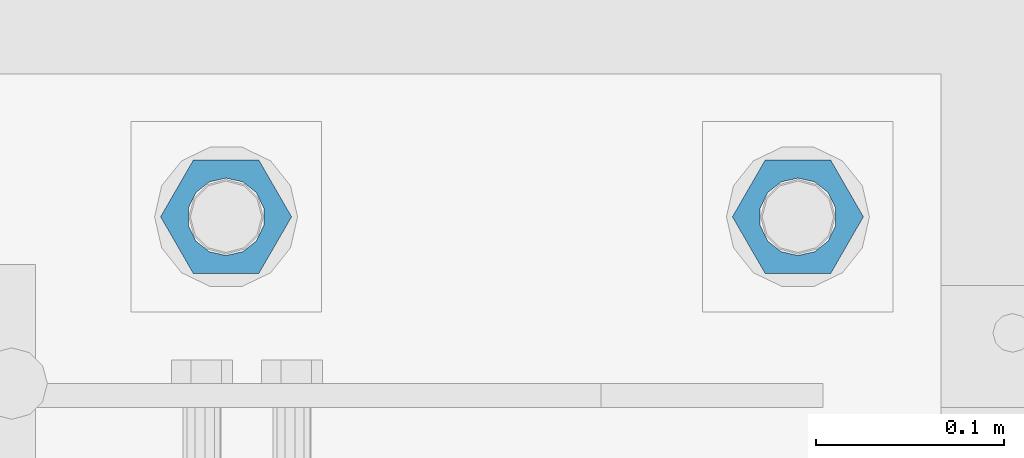
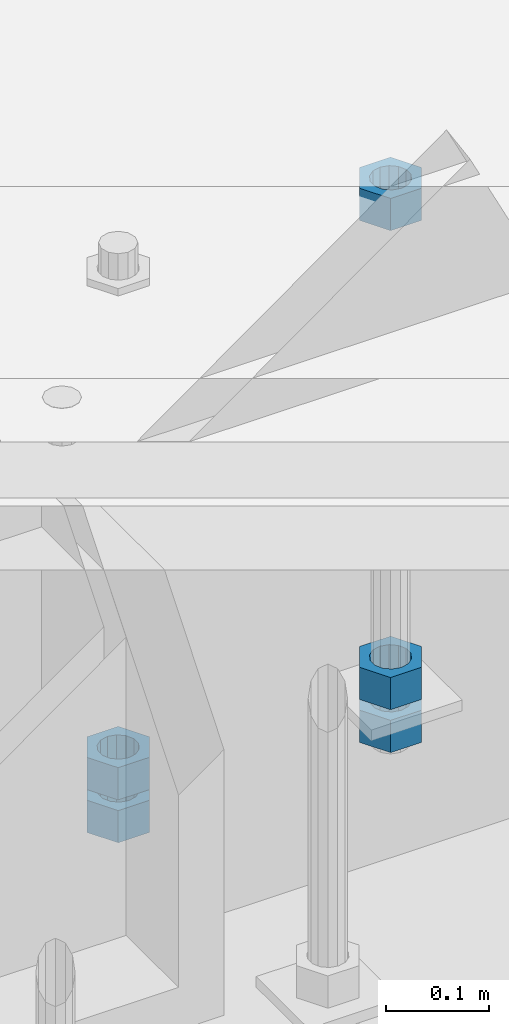
# One storey, part 996 of 1763: 5 columns, 1 element without a shape of its own.
"""IFC2X3 building model written with IfcOpenShell, lengths in millimetres."""

import ifcopenshell
import ifcopenshell.guid

model = None  # the IFC model being written
_history = None  # IfcOwnerHistory: only IFC2X3 demands one
_inside = {}  # id of a spatial element -> (the spatial element, [elements in it])
_under = {}  # id of a project, library or spatial element -> (it, [spatial elements below it])
_declared = {}  # id of a project -> (the project, [libraries it declares])
_typed = {}  # id of a type object -> (the type object, [elements of that type])
_made_of = {}  # id of a material, layer set ... -> (it, [elements and type objects made of it])


def new_model(schema):
    """Start an empty IFC model of exactly this schema.

    Asked for "IFC4X3", IfcOpenShell would pick the latest addendum, in which some entities
    have other attributes; the version numbers below select the first issue.
    IFC2X3 requires an IfcOwnerHistory on every rooted entity: one is made here for all.
    """
    global model, _history
    if schema == "IFC4X3":
        model = ifcopenshell.file(schema_version=(4, 3, 0, 0))
    else:
        model = ifcopenshell.file(schema=schema)
    _inside.clear()
    _under.clear()
    _declared.clear()
    _typed.clear()
    _made_of.clear()
    _history = None
    if model.schema == "IFC2X3":
        org = make("IfcOrganization", Name="unknown")
        user = make(
            "IfcPersonAndOrganization",
            ThePerson=make("IfcPerson", FamilyName="unknown"),
            TheOrganization=org,
        )
        app = make(
            "IfcApplication",
            ApplicationDeveloper=org,
            Version="unknown",
            ApplicationFullName="unknown",
            ApplicationIdentifier="unknown",
        )
        _history = make(
            "IfcOwnerHistory",
            OwningUser=user,
            OwningApplication=app,
            ChangeAction="ADDED",
            CreationDate=0,
        )
    return model


def make(cls, **values):
    """One entity of the class cls with the attributes given. An attribute that is None is left unset."""
    return model.create_entity(
        cls, **{name: value for name, value in values.items() if value is not None}
    )


def rooted(cls, **values):
    """An entity with a GlobalId (a new one), such as an element, a storey or a relation."""
    return make(cls, GlobalId=ifcopenshell.guid.new(), OwnerHistory=_history, **values)


def si_unit(unit_type, name, prefix=None):
    """IfcSIUnit, for example si_unit("LENGTHUNIT", "METRE", prefix="MILLI")."""
    return make("IfcSIUnit", UnitType=unit_type, Prefix=prefix, Name=name)


def assignment(units):
    """IfcUnitAssignment: the units of a project."""
    return None if units is None else make("IfcUnitAssignment", Units=units)


def point(xyz):
    """IfcCartesianPoint."""
    return None if xyz is None else make("IfcCartesianPoint", Coordinates=xyz)


def direction(xyz):
    """IfcDirection."""
    return None if xyz is None else make("IfcDirection", DirectionRatios=xyz)


def frame(location, z_axis=None, x_axis=None):
    """IfcAxis2Placement3D, a coordinate frame: its origin and axes. An axis left out is left unset."""
    return make(
        "IfcAxis2Placement3D",
        Location=point(location),
        Axis=direction(z_axis),
        RefDirection=direction(x_axis),
    )


def origin_with_axes():
    """The frame at (0, 0, 0) with the z axis (0, 0, 1) and the x axis (1, 0, 0) written out."""
    return frame((0.0, 0.0, 0.0), z_axis=(0.0, 0.0, 1.0), x_axis=(1.0, 0.0, 0.0))


def place(relative_to, where):
    """IfcLocalPlacement: puts the frame where relative to a parent placement (None: the world)."""
    return make(
        "IfcLocalPlacement", PlacementRelTo=relative_to, RelativePlacement=where
    )


def context(
    kind, dimensions, precision=None, world=None, true_north=None, identifier=None
):
    """IfcGeometricRepresentationContext, for example the 3D "Model" context."""
    return make(
        "IfcGeometricRepresentationContext",
        ContextIdentifier=identifier,
        ContextType=kind,
        CoordinateSpaceDimension=dimensions,
        Precision=precision,
        WorldCoordinateSystem=world,
        TrueNorth=true_north,
    )


def subcontext(parent, identifier, kind, view, scale=None):
    """IfcGeometricRepresentationSubContext, for example "Body" below "Model"."""
    return make(
        "IfcGeometricRepresentationSubContext",
        ContextIdentifier=identifier,
        ContextType=kind,
        ParentContext=parent,
        TargetScale=scale,
        TargetView=view,
    )


def project(units=None, contexts=None):
    """IfcProject with its units and contexts."""
    return rooted(
        "IfcProject",
        Name="project",
        RepresentationContexts=contexts,
        UnitsInContext=assignment(units),
    )


def spatial(cls, under=None, at=None, **own):
    """A site, building, storey or space (cls), placed at a placement, below another one or the project."""
    s = rooted(cls, ObjectPlacement=at, **own)
    if under is not None:
        _under.setdefault(under.id(), (under, []))[1].append(s)
    return s


def faces_of(points, faces, orient=None, outer=None):
    """IfcFace entities. A face is a list of loops; a loop is a list of indices into points, from 0.

    orient and outer hold one flag for each loop. By default every Orientation is true, the
    first loop of a face is its IfcFaceOuterBound and the others are IfcFaceBound.
    """
    made = []
    for i, loops in enumerate(faces):
        bounds = []
        for j, loop in enumerate(loops):
            is_outer = j == 0 if outer is None else outer[i][j]
            bounds.append(
                make(
                    "IfcFaceOuterBound" if is_outer else "IfcFaceBound",
                    Bound=make("IfcPolyLoop", Polygon=[points[k] for k in loop]),
                    Orientation=True if orient is None else orient[i][j],
                )
            )
        made.append(make("IfcFace", Bounds=bounds))
    return made


def faceted_brep(points, faces, orient=None, outer=None, voids=None):
    """IfcFacetedBrep: a solid bounded by flat faces; with voids (closed shells), ...WithVoids."""
    shared = [point(p) for p in points]
    hull = make("IfcClosedShell", CfsFaces=faces_of(shared, faces, orient, outer))
    if voids is None:
        return make("IfcFacetedBrep", Outer=hull)
    return make(
        "IfcFacetedBrepWithVoids",
        Outer=hull,
        Voids=[
            make(cls, CfsFaces=faces_of(shared, fs, o, b)) for cls, fs, o, b in voids
        ],
    )


def shape(context_of_items, identifier, shape_type, items):
    """IfcShapeRepresentation: the items that make up one representation, for example the "Body"."""
    return make(
        "IfcShapeRepresentation",
        ContextOfItems=context_of_items,
        RepresentationIdentifier=identifier,
        RepresentationType=shape_type,
        Items=items,
    )


def material(Name=None, Category=None):
    """IfcMaterial."""
    return make("IfcMaterial", Name=Name, Category=Category)


def made_of(thing, what):
    """Note that an element or type object is made of a material, layer set ...; save() writes the relation."""
    if what is not None:
        _made_of.setdefault(what.id(), (what, []))[1].append(thing)
    return thing


def type_object(cls, material=None, **own):
    """A type object (cls), such as IfcWallType, which elements share."""
    return made_of(rooted(cls, **own), material)


def element(
    cls,
    number,
    at=None,
    inside=None,
    cuts=None,
    type_object=None,
    material=None,
    context=None,
    identifier="Body",
    shape_type=None,
    held_by="IfcProductDefinitionShape",
    body=None,
    shapes=None,
    **own,
):
    """One element of the class cls, such as IfcWall. Its Tag is "e" and its number.

    at: its placement. inside: the storey or other place that contains it. cuts: it is an
    opening in that element (IfcRelVoidsElement). A single representation is given by context,
    identifier, shape_type and body (its items); several are given by shapes. held_by: the class
    of the entity that holds the representations. save() writes the other relations.
    """
    e = rooted(cls, Tag="e%d" % number, ObjectPlacement=at, **own)
    if body is not None:
        shapes = [shape(context, identifier, shape_type, body)]
    if shapes is not None:
        e.Representation = make(held_by, Representations=shapes)
    if inside is not None:
        _inside.setdefault(inside.id(), (inside, []))[1].append(e)
    if cuts is not None:
        rooted(
            "IfcRelVoidsElement", RelatingBuildingElement=cuts, RelatedOpeningElement=e
        )
    if type_object is not None:
        _typed.setdefault(type_object.id(), (type_object, []))[1].append(e)
    return made_of(e, material)


def aggregate(whole, parts):
    """IfcRelAggregates: a whole, such as a stair, and the parts it consists of."""
    return rooted("IfcRelAggregates", RelatingObject=whole, RelatedObjects=parts)


def save(model, path):
    """Write the relations noted so far, then the file.

    IfcRelAggregates (storeys below a building ...), IfcRelContainedInSpatialStructure (elements
    in a storey), IfcRelDefinesByType, IfcRelAssociatesMaterial and IfcRelDeclares: one each for
    every whole, place, type object, material and project.
    """
    for whole, parts in _under.values():
        aggregate(whole, parts)
    for where, things in _inside.values():
        rooted(
            "IfcRelContainedInSpatialStructure",
            RelatedElements=things,
            RelatingStructure=where,
        )
    for kind, things in _typed.values():
        rooted("IfcRelDefinesByType", RelatedObjects=things, RelatingType=kind)
    for what, things in _made_of.values():
        rooted("IfcRelAssociatesMaterial", RelatedObjects=things, RelatingMaterial=what)
    for by, libraries in _declared.values():
        rooted("IfcRelDeclares", RelatingContext=by, RelatedDefinitions=libraries)
    model.write(path)


model = new_model("IFC2X3")

# Units and contexts
model_context = context("Model", 3, precision=1e-05, world=origin_with_axes())
body_context = subcontext(model_context, "Body", "Model", "MODEL_VIEW")
ifc_project = project(units=[si_unit("LENGTHUNIT", "METRE", prefix="MILLI"), si_unit("AREAUNIT", "SQUARE_METRE"), si_unit("VOLUMEUNIT", "CUBIC_METRE"), si_unit("MASSUNIT", "GRAM", prefix="KILO"), si_unit("TIMEUNIT", "SECOND"), si_unit("PLANEANGLEUNIT", "RADIAN"), si_unit("SOLIDANGLEUNIT", "STERADIAN"), si_unit("THERMODYNAMICTEMPERATUREUNIT", "DEGREE_CELSIUS"), si_unit("LUMINOUSINTENSITYUNIT", "LUMEN")], contexts=[model_context])

# Site, building, storey
site_placement = place(None, origin_with_axes())
site = spatial("IfcSite", under=ifc_project, at=site_placement, CompositionType="ELEMENT")
building_placement = place(site_placement, origin_with_axes())
building = spatial("IfcBuilding", under=site, at=building_placement, Name="Undefined", CompositionType="ELEMENT")
storey_placement = place(building_placement, origin_with_axes())
storey = spatial("IfcBuildingStorey", under=building, at=storey_placement, Name="Undefined", CompositionType="ELEMENT", Elevation=0.0)

# Assembly, columns
assembly_placement = place(storey_placement, origin_with_axes())
assembly = element("IfcElementAssembly", 1, at=assembly_placement, inside=storey, Name="TEMPLATE", AssemblyPlace="NOTDEFINED", PredefinedType="RIGID_FRAME")
ifc_material = material(Name="STEEL/A563")
column_type = type_object("IfcColumnType", Name="1-1/2_HEAVY_HEX_NUT", PredefinedType="NOTDEFINED")
column_1_placement = place(assembly_placement, frame((-34645.0372736983, -13512.8, 4622.8), z_axis=(0.0, 1.0, 0.0), x_axis=(0.0, 0.0, -1.0)))
column_1 = element("IfcColumn", 2, at=column_1_placement, type_object=column_type, material=ifc_material, Name="NUT", ObjectType="1-1/2_HEAVY_HEX_NUT", context=body_context, shape_type="Brep", body=[
    faceted_brep([(0.0, -34.9199981689453, 0.0), (0.0, -17.4599990844727, -30.25), (38.1000000000004, -17.4599990844727, -30.25), (38.1000000000004, -34.9199981689453, 0.0), (0.0, 17.4599990844727, -30.25), (38.1000000000004, 17.4599990844727, -30.25), (0.0, 34.9199981689453, 0.0), (38.1000000000004, 34.9199981689453, 0.0), (0.0, 17.4599990844727, 30.25), (38.1000000000004, 17.4599990844727, 30.25), (0.0, -17.4599990844727, 30.25), (38.1000000000004, -17.4599990844727, 30.25), (0.0, 0.0, 20.6399993896484), (0.0, 8.95536011056538, 18.5959968835978), (38.1000000000004, 8.95536011056538, 18.5959968835978), (38.1000000000004, 0.0, 20.6399993896484), (0.0, 16.1370013209453, 12.8688291298167), (38.1000000000004, 16.1370013209453, 12.8688291298167), (0.0, 20.1225115123816, 4.59283194104137), (38.1000000000004, 20.1225115123816, 4.59283194104137), (0.0, 20.1225115123816, -4.59283194104319), (38.1000000000004, 20.1225115123816, -4.59283194104319), (0.0, 16.1370013209453, -12.8688291298167), (38.1000000000004, 16.1370013209453, -12.8688291298167), (0.0, 8.95536011056538, -18.5959968835978), (38.1000000000004, 8.95536011056538, -18.5959968835978), (0.0, 0.0, -20.6399993896484), (38.1000000000004, 0.0, -20.6399993896484), (0.0, -8.95536011056538, -18.5959968835978), (38.1000000000004, -8.95536011056538, -18.5959968835978), (0.0, -16.1370013209453, -12.8688291298167), (38.1000000000004, -16.1370013209453, -12.8688291298167), (0.0, -20.1225115123816, -4.59283194104137), (38.1000000000004, -20.1225115123816, -4.59283194104137), (0.0, -20.1225115123816, 4.59283194104319), (38.1000000000004, -20.1225115123816, 4.59283194104319), (0.0, -16.1370013209453, 12.8688291298167), (38.1000000000004, -16.1370013209453, 12.8688291298167), (0.0, -8.95536011056538, 18.5959968835978), (38.1000000000004, -8.95536011056538, 18.5959968835978)], [[[0, 1, 2, 3]], [[1, 4, 5, 2]], [[4, 6, 7, 5]], [[6, 8, 9, 7]], [[8, 10, 11, 9]], [[10, 0, 3, 11]], [[12, 13, 14, 15]], [[13, 16, 17, 14]], [[16, 18, 19, 17]], [[18, 20, 21, 19]], [[20, 22, 23, 21]], [[22, 24, 25, 23]], [[24, 26, 27, 25]], [[26, 28, 29, 27]], [[28, 30, 31, 29]], [[30, 32, 33, 31]], [[32, 34, 35, 33]], [[34, 36, 37, 35]], [[36, 38, 39, 37]], [[38, 12, 15, 39]], [[5, 7, 9, 11, 3, 2], [17, 19, 21, 23, 25, 27, 29, 31, 33, 35, 37, 39, 15, 14]], [[10, 8, 6, 4, 1, 0], [38, 36, 34, 32, 30, 28, 26, 24, 22, 20, 18, 16, 13, 12]]]),
])
column_2_placement = place(assembly_placement, frame((-34645.0372736983, -13512.8, 4572.0), z_axis=(0.0, 1.0, 0.0), x_axis=(0.0, 0.0, -1.0)))
column_2 = element("IfcColumn", 3, at=column_2_placement, type_object=column_type, material=ifc_material, Name="NUT", ObjectType="1-1/2_HEAVY_HEX_NUT", context=body_context, shape_type="Brep", body=[
    faceted_brep([(0.0, -34.9199981689453, 0.0), (0.0, -17.4599990844727, -30.25), (38.1000000000004, -17.4599990844727, -30.25), (38.1000000000004, -34.9199981689453, 0.0), (0.0, 17.4599990844727, -30.25), (38.1000000000004, 17.4599990844727, -30.25), (0.0, 34.9199981689453, 0.0), (38.1000000000004, 34.9199981689453, 0.0), (0.0, 17.4599990844727, 30.25), (38.1000000000004, 17.4599990844727, 30.25), (0.0, -17.4599990844727, 30.25), (38.1000000000004, -17.4599990844727, 30.25), (0.0, 0.0, 20.6399993896484), (0.0, 8.95536011056538, 18.5959968835978), (38.1000000000004, 8.95536011056538, 18.5959968835978), (38.1000000000004, 0.0, 20.6399993896484), (0.0, 16.1370013209453, 12.8688291298167), (38.1000000000004, 16.1370013209453, 12.8688291298167), (0.0, 20.1225115123816, 4.59283194104137), (38.1000000000004, 20.1225115123816, 4.59283194104137), (0.0, 20.1225115123816, -4.59283194104319), (38.1000000000004, 20.1225115123816, -4.59283194104319), (0.0, 16.1370013209453, -12.8688291298167), (38.1000000000004, 16.1370013209453, -12.8688291298167), (0.0, 8.95536011056538, -18.5959968835978), (38.1000000000004, 8.95536011056538, -18.5959968835978), (0.0, 0.0, -20.6399993896484), (38.1000000000004, 0.0, -20.6399993896484), (0.0, -8.95536011056538, -18.5959968835978), (38.1000000000004, -8.95536011056538, -18.5959968835978), (0.0, -16.1370013209453, -12.8688291298167), (38.1000000000004, -16.1370013209453, -12.8688291298167), (0.0, -20.1225115123816, -4.59283194104137), (38.1000000000004, -20.1225115123816, -4.59283194104137), (0.0, -20.1225115123816, 4.59283194104319), (38.1000000000004, -20.1225115123816, 4.59283194104319), (0.0, -16.1370013209453, 12.8688291298167), (38.1000000000004, -16.1370013209453, 12.8688291298167), (0.0, -8.95536011056538, 18.5959968835978), (38.1000000000004, -8.95536011056538, 18.5959968835978)], [[[0, 1, 2, 3]], [[1, 4, 5, 2]], [[4, 6, 7, 5]], [[6, 8, 9, 7]], [[8, 10, 11, 9]], [[10, 0, 3, 11]], [[12, 13, 14, 15]], [[13, 16, 17, 14]], [[16, 18, 19, 17]], [[18, 20, 21, 19]], [[20, 22, 23, 21]], [[22, 24, 25, 23]], [[24, 26, 27, 25]], [[26, 28, 29, 27]], [[28, 30, 31, 29]], [[30, 32, 33, 31]], [[32, 34, 35, 33]], [[34, 36, 37, 35]], [[36, 38, 39, 37]], [[38, 12, 15, 39]], [[5, 7, 9, 11, 3, 2], [17, 19, 21, 23, 25, 27, 29, 31, 33, 35, 37, 39, 15, 14]], [[10, 8, 6, 4, 1, 0], [38, 36, 34, 32, 30, 28, 26, 24, 22, 20, 18, 16, 13, 12]]]),
])
column_3_placement = place(assembly_placement, frame((-34340.2372736983, -13512.8, 5189.5375), z_axis=(0.0, 1.0, 0.0), x_axis=(0.0, 0.0, -1.0)))
column_3 = element("IfcColumn", 4, at=column_3_placement, type_object=column_type, material=ifc_material, Name="NUT", ObjectType="1-1/2_HEAVY_HEX_NUT", context=body_context, shape_type="Brep", body=[
    faceted_brep([(0.0, -34.9199981689453, 0.0), (0.0, -17.4599990844727, -30.25), (38.1000000000004, -17.4599990844727, -30.25), (38.1000000000004, -34.9199981689453, 0.0), (0.0, 17.4599990844727, -30.25), (38.1000000000004, 17.4599990844727, -30.25), (0.0, 34.9199981689453, 0.0), (38.1000000000004, 34.9199981689453, 0.0), (0.0, 17.4599990844727, 30.25), (38.1000000000004, 17.4599990844727, 30.25), (0.0, -17.4599990844727, 30.25), (38.1000000000004, -17.4599990844727, 30.25), (0.0, 0.0, 20.6399993896484), (0.0, 8.95536011056538, 18.5959968835978), (38.1000000000004, 8.95536011056538, 18.5959968835978), (38.1000000000004, 0.0, 20.6399993896484), (0.0, 16.1370013209453, 12.8688291298167), (38.1000000000004, 16.1370013209453, 12.8688291298167), (0.0, 20.1225115123816, 4.59283194104137), (38.1000000000004, 20.1225115123816, 4.59283194104137), (0.0, 20.1225115123816, -4.59283194104319), (38.1000000000004, 20.1225115123816, -4.59283194104319), (0.0, 16.1370013209453, -12.8688291298167), (38.1000000000004, 16.1370013209453, -12.8688291298167), (0.0, 8.95536011056538, -18.5959968835978), (38.1000000000004, 8.95536011056538, -18.5959968835978), (0.0, 0.0, -20.6399993896484), (38.1000000000004, 0.0, -20.6399993896484), (0.0, -8.95536011056538, -18.5959968835978), (38.1000000000004, -8.95536011056538, -18.5959968835978), (0.0, -16.1370013209453, -12.8688291298167), (38.1000000000004, -16.1370013209453, -12.8688291298167), (0.0, -20.1225115123816, -4.59283194104137), (38.1000000000004, -20.1225115123816, -4.59283194104137), (0.0, -20.1225115123816, 4.59283194104319), (38.1000000000004, -20.1225115123816, 4.59283194104319), (0.0, -16.1370013209453, 12.8688291298167), (38.1000000000004, -16.1370013209453, 12.8688291298167), (0.0, -8.95536011056538, 18.5959968835978), (38.1000000000004, -8.95536011056538, 18.5959968835978)], [[[0, 1, 2, 3]], [[1, 4, 5, 2]], [[4, 6, 7, 5]], [[6, 8, 9, 7]], [[8, 10, 11, 9]], [[10, 0, 3, 11]], [[12, 13, 14, 15]], [[13, 16, 17, 14]], [[16, 18, 19, 17]], [[18, 20, 21, 19]], [[20, 22, 23, 21]], [[22, 24, 25, 23]], [[24, 26, 27, 25]], [[26, 28, 29, 27]], [[28, 30, 31, 29]], [[30, 32, 33, 31]], [[32, 34, 35, 33]], [[34, 36, 37, 35]], [[36, 38, 39, 37]], [[38, 12, 15, 39]], [[5, 7, 9, 11, 3, 2], [17, 19, 21, 23, 25, 27, 29, 31, 33, 35, 37, 39, 15, 14]], [[10, 8, 6, 4, 1, 0], [38, 36, 34, 32, 30, 28, 26, 24, 22, 20, 18, 16, 13, 12]]]),
])
column_4_placement = place(assembly_placement, frame((-34340.2372736983, -13512.8, 4622.8), z_axis=(0.0, 1.0, 0.0), x_axis=(0.0, 0.0, -1.0)))
column_4 = element("IfcColumn", 5, at=column_4_placement, type_object=column_type, material=ifc_material, Name="NUT", ObjectType="1-1/2_HEAVY_HEX_NUT", context=body_context, shape_type="Brep", body=[
    faceted_brep([(0.0, -34.9199981689453, 0.0), (0.0, -17.4599990844727, -30.25), (38.1000000000004, -17.4599990844727, -30.25), (38.1000000000004, -34.9199981689453, 0.0), (0.0, 17.4599990844727, -30.25), (38.1000000000004, 17.4599990844727, -30.25), (0.0, 34.9199981689453, 0.0), (38.1000000000004, 34.9199981689453, 0.0), (0.0, 17.4599990844727, 30.25), (38.1000000000004, 17.4599990844727, 30.25), (0.0, -17.4599990844727, 30.25), (38.1000000000004, -17.4599990844727, 30.25), (0.0, 0.0, 20.6399993896484), (0.0, 8.95536011056538, 18.5959968835978), (38.1000000000004, 8.95536011056538, 18.5959968835978), (38.1000000000004, 0.0, 20.6399993896484), (0.0, 16.1370013209453, 12.8688291298167), (38.1000000000004, 16.1370013209453, 12.8688291298167), (0.0, 20.1225115123816, 4.59283194104137), (38.1000000000004, 20.1225115123816, 4.59283194104137), (0.0, 20.1225115123816, -4.59283194104319), (38.1000000000004, 20.1225115123816, -4.59283194104319), (0.0, 16.1370013209453, -12.8688291298167), (38.1000000000004, 16.1370013209453, -12.8688291298167), (0.0, 8.95536011056538, -18.5959968835978), (38.1000000000004, 8.95536011056538, -18.5959968835978), (0.0, 0.0, -20.6399993896484), (38.1000000000004, 0.0, -20.6399993896484), (0.0, -8.95536011056538, -18.5959968835978), (38.1000000000004, -8.95536011056538, -18.5959968835978), (0.0, -16.1370013209453, -12.8688291298167), (38.1000000000004, -16.1370013209453, -12.8688291298167), (0.0, -20.1225115123816, -4.59283194104137), (38.1000000000004, -20.1225115123816, -4.59283194104137), (0.0, -20.1225115123816, 4.59283194104319), (38.1000000000004, -20.1225115123816, 4.59283194104319), (0.0, -16.1370013209453, 12.8688291298167), (38.1000000000004, -16.1370013209453, 12.8688291298167), (0.0, -8.95536011056538, 18.5959968835978), (38.1000000000004, -8.95536011056538, 18.5959968835978)], [[[0, 1, 2, 3]], [[1, 4, 5, 2]], [[4, 6, 7, 5]], [[6, 8, 9, 7]], [[8, 10, 11, 9]], [[10, 0, 3, 11]], [[12, 13, 14, 15]], [[13, 16, 17, 14]], [[16, 18, 19, 17]], [[18, 20, 21, 19]], [[20, 22, 23, 21]], [[22, 24, 25, 23]], [[24, 26, 27, 25]], [[26, 28, 29, 27]], [[28, 30, 31, 29]], [[30, 32, 33, 31]], [[32, 34, 35, 33]], [[34, 36, 37, 35]], [[36, 38, 39, 37]], [[38, 12, 15, 39]], [[5, 7, 9, 11, 3, 2], [17, 19, 21, 23, 25, 27, 29, 31, 33, 35, 37, 39, 15, 14]], [[10, 8, 6, 4, 1, 0], [38, 36, 34, 32, 30, 28, 26, 24, 22, 20, 18, 16, 13, 12]]]),
])
column_5_placement = place(assembly_placement, frame((-34340.2372736983, -13512.8, 4572.0), z_axis=(0.0, 1.0, 0.0), x_axis=(0.0, 0.0, -1.0)))
column_5 = element("IfcColumn", 6, at=column_5_placement, type_object=column_type, material=ifc_material, Name="NUT", ObjectType="1-1/2_HEAVY_HEX_NUT", context=body_context, shape_type="Brep", body=[
    faceted_brep([(0.0, -34.9199981689453, 0.0), (0.0, -17.4599990844727, -30.25), (38.1000000000004, -17.4599990844727, -30.25), (38.1000000000004, -34.9199981689453, 0.0), (0.0, 17.4599990844727, -30.25), (38.1000000000004, 17.4599990844727, -30.25), (0.0, 34.9199981689453, 0.0), (38.1000000000004, 34.9199981689453, 0.0), (0.0, 17.4599990844727, 30.25), (38.1000000000004, 17.4599990844727, 30.25), (0.0, -17.4599990844727, 30.25), (38.1000000000004, -17.4599990844727, 30.25), (0.0, 0.0, 20.6399993896484), (0.0, 8.95536011056538, 18.5959968835978), (38.1000000000004, 8.95536011056538, 18.5959968835978), (38.1000000000004, 0.0, 20.6399993896484), (0.0, 16.1370013209453, 12.8688291298167), (38.1000000000004, 16.1370013209453, 12.8688291298167), (0.0, 20.1225115123816, 4.59283194104137), (38.1000000000004, 20.1225115123816, 4.59283194104137), (0.0, 20.1225115123816, -4.59283194104319), (38.1000000000004, 20.1225115123816, -4.59283194104319), (0.0, 16.1370013209453, -12.8688291298167), (38.1000000000004, 16.1370013209453, -12.8688291298167), (0.0, 8.95536011056538, -18.5959968835978), (38.1000000000004, 8.95536011056538, -18.5959968835978), (0.0, 0.0, -20.6399993896484), (38.1000000000004, 0.0, -20.6399993896484), (0.0, -8.95536011056538, -18.5959968835978), (38.1000000000004, -8.95536011056538, -18.5959968835978), (0.0, -16.1370013209453, -12.8688291298167), (38.1000000000004, -16.1370013209453, -12.8688291298167), (0.0, -20.1225115123816, -4.59283194104137), (38.1000000000004, -20.1225115123816, -4.59283194104137), (0.0, -20.1225115123816, 4.59283194104319), (38.1000000000004, -20.1225115123816, 4.59283194104319), (0.0, -16.1370013209453, 12.8688291298167), (38.1000000000004, -16.1370013209453, 12.8688291298167), (0.0, -8.95536011056538, 18.5959968835978), (38.1000000000004, -8.95536011056538, 18.5959968835978)], [[[0, 1, 2, 3]], [[1, 4, 5, 2]], [[4, 6, 7, 5]], [[6, 8, 9, 7]], [[8, 10, 11, 9]], [[10, 0, 3, 11]], [[12, 13, 14, 15]], [[13, 16, 17, 14]], [[16, 18, 19, 17]], [[18, 20, 21, 19]], [[20, 22, 23, 21]], [[22, 24, 25, 23]], [[24, 26, 27, 25]], [[26, 28, 29, 27]], [[28, 30, 31, 29]], [[30, 32, 33, 31]], [[32, 34, 35, 33]], [[34, 36, 37, 35]], [[36, 38, 39, 37]], [[38, 12, 15, 39]], [[5, 7, 9, 11, 3, 2], [17, 19, 21, 23, 25, 27, 29, 31, 33, 35, 37, 39, 15, 14]], [[10, 8, 6, 4, 1, 0], [38, 36, 34, 32, 30, 28, 26, 24, 22, 20, 18, 16, 13, 12]]]),
])
aggregate(assembly, [column_1, column_2, column_3, column_4, column_5])

save(model, "model.ifc")
